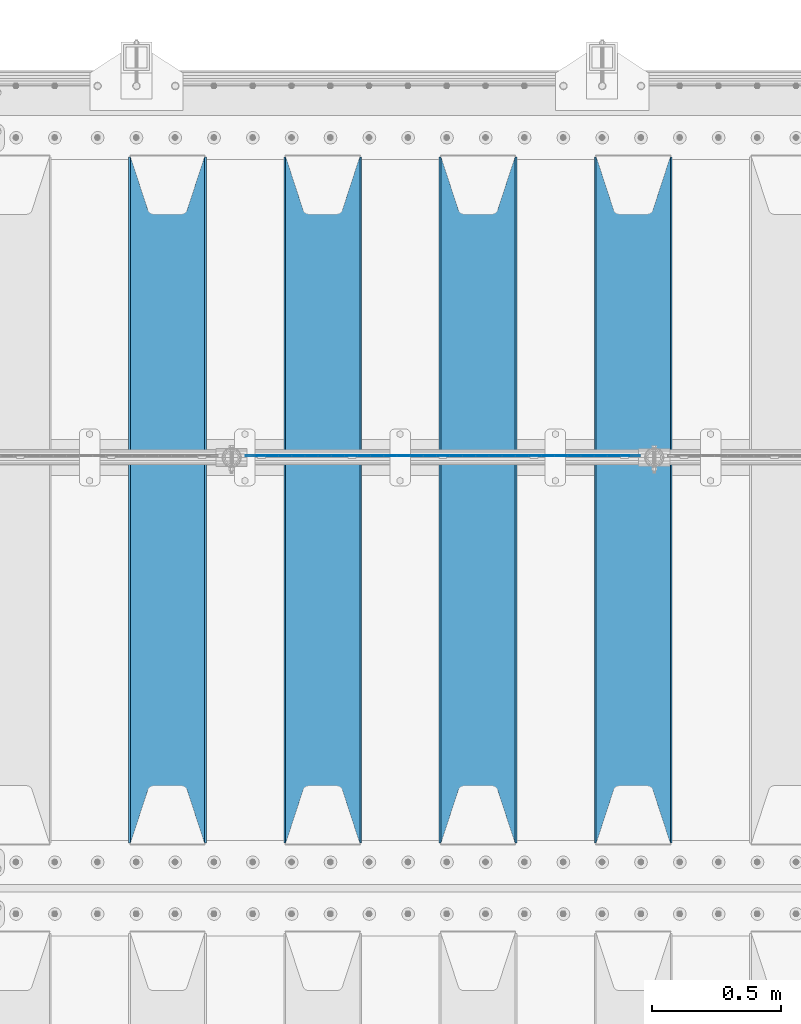
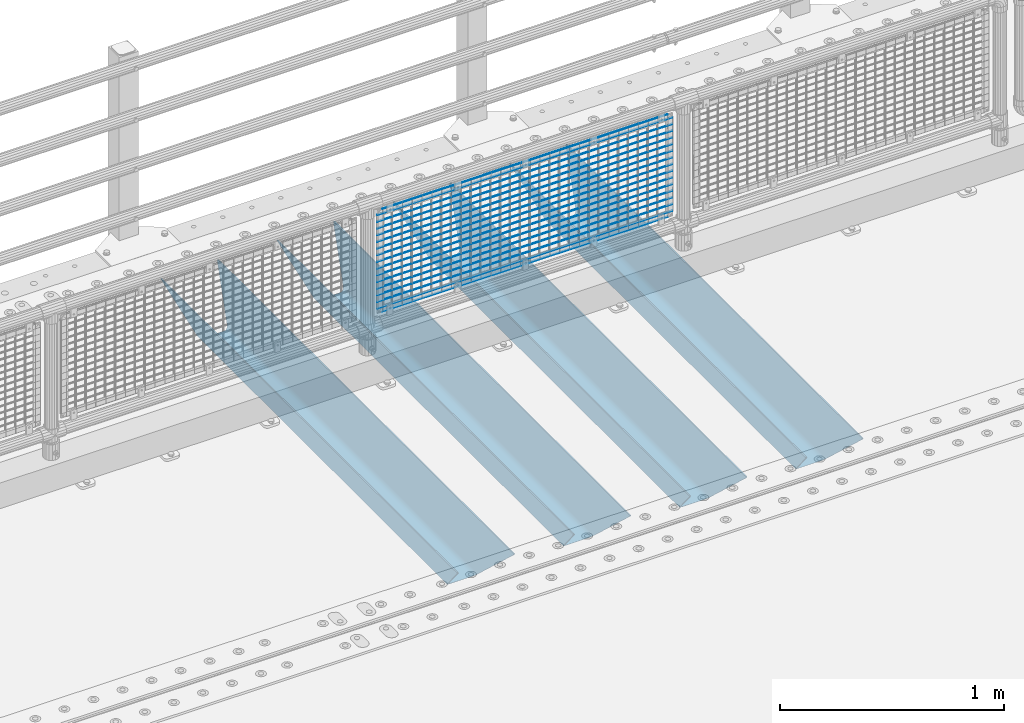
# One storey, part 145 of 270: 21 beams.
"""IFC2X3 building model written with IfcOpenShell, lengths in millimetres."""

from ifc_helpers import new_model, si_unit, frame, origin_with_axes, place, context, subcontext, project, spatial, faceted_brep, material, type_object, element, save


model = new_model("IFC2X3")

# Units and contexts
model_context = context("Model", 3, precision=1e-05, world=origin_with_axes())
body_context = subcontext(model_context, "Body", "Model", "MODEL_VIEW")
ifc_project = project(units=[si_unit("LENGTHUNIT", "METRE", prefix="MILLI"), si_unit("AREAUNIT", "SQUARE_METRE"), si_unit("VOLUMEUNIT", "CUBIC_METRE"), si_unit("MASSUNIT", "GRAM", prefix="KILO"), si_unit("TIMEUNIT", "SECOND"), si_unit("PLANEANGLEUNIT", "RADIAN"), si_unit("SOLIDANGLEUNIT", "STERADIAN"), si_unit("THERMODYNAMICTEMPERATUREUNIT", "DEGREE_CELSIUS"), si_unit("LUMINOUSINTENSITYUNIT", "LUMEN")], contexts=[model_context])

# Site, building, storey
site_placement = place(None, origin_with_axes())
site = spatial("IfcSite", under=ifc_project, at=site_placement, CompositionType="ELEMENT")
building_placement = place(site_placement, origin_with_axes())
building = spatial("IfcBuilding", under=site, at=building_placement, Name="Standard", CompositionType="ELEMENT")
storey_placement = place(building_placement, origin_with_axes())
storey = spatial("IfcBuildingStorey", under=building, at=storey_placement, Name="Undefined", CompositionType="ELEMENT", Elevation=0.0)

# Beams
ifc_material_1 = material(Name="STEEL/S355N")
beam_type_1 = type_object("IfcBeamType", PredefinedType="NOTDEFINED")
beam_1_placement = place(storey_placement, frame((16870.0, -17825.0, -115.0), z_axis=(0.0, 0.0, 1.0), x_axis=(0.0, 1.0, 0.0)))
element("IfcBeam", 1, at=beam_1_placement, inside=storey, type_object=beam_type_1, material=ifc_material_1, context=body_context, shape_type="Brep", body=[
    faceted_brep([(0.0, 150.0, 115.0), (0.0, 143.689999999999, 115.0), (2650.00000000297, 143.689999999999, 115.0), (2650.00000000297, 150.0, 115.0), (2650.00000000297, 142.059565218398, 110.000000003096), (2650.00000000297, 148.3695652184, 110.000000003096), (2441.90079219209, -80.1103600731112, -98.0992078077845), (2437.7588105432, -77.5672621345584, -102.241189456673), (2434.06523489747, -74.4080125315522, -105.934765102404), (2430.9108609509, -70.710272125576, -109.089139048974), (2428.37322971128, -66.5649389910068, -111.626770288588), (2426.51472138055, -62.0739139532889, -113.485278619323), (2425.38102192092, -57.3475956567672, -114.618978078955), (2424.99999999987, -52.5021667386536, -115.0), (2424.99999999987, 52.5021667386536, -115.0), (2425.38102192092, 57.3475956567672, -114.618978078955), (2426.51472138055, 62.0739139532889, -113.485278619323), (2428.37322971128, 66.5649389910068, -111.626770288588), (2430.9108609509, 70.710272125576, -109.089139048974), (2434.06523489747, 74.4080125315522, -105.934765102404), (2437.7588105432, 77.5672621345584, -102.241189456673), (2441.90079219209, 80.1103600731112, -98.0992078077846), (2446.38936140511, 81.9747917625791, -93.6106385947584), (2448.2494850041, 76.2713538057251, -91.7505149957729), (2444.62967112263, 74.76777986261, -95.3703288772456), (2441.28936334126, 72.7168944282894, -98.710636658607), (2438.31067330439, 70.1691124903846, -101.689326695487), (2435.76682334747, 67.1870637758839, -104.233176652398), (2433.72034654133, 63.8440531834895, -106.279653458539), (2432.22154950042, 60.222258798236, -107.778450499454), (2431.30727574265, 56.4107117849089, -108.692724257221), (2430.99999999987, 52.5031078186876, -109.0), (2430.99999999987, -52.5031078186876, -109.0), (2431.30727574265, -56.4107117849089, -108.692724257221), (2432.22154950042, -60.222258798236, -107.778450499454), (2433.72034654133, -63.8440531834895, -106.279653458539), (2435.76682334747, -67.1870637758839, -104.233176652398), (2438.31067330438, -70.1691124903846, -101.689326695487), (2441.28936334126, -72.7168944282894, -98.7106366586071), (2444.62967112263, -74.76777986261, -95.3703288772457), (2448.2494850041, -76.2713538057251, -91.7505149957729), (2650.00000000297, -142.059565218398, 110.000000003096), (2650.00000000297, -148.3695652184, 110.000000003096), (2446.38936140511, -81.9747917625791, -93.6106385947584), (2650.00000000297, -143.689999999999, 115.0), (2650.00000000297, -150.0, 115.0), (0.0, -143.689999999999, 115.0), (0.0, -150.0, 115.0), (0.0, -148.369565218261, 110.000000002672), (203.610638597431, -81.9747917625791, -93.6106385947584), (208.099207810457, -80.1103600731112, -98.0992078077845), (212.241189459342, -77.5672621345584, -102.241189456673), (215.934765105078, -74.4080125315522, -105.934765102404), (219.089139051644, -70.710272125576, -109.089139048974), (221.626770291259, -66.5649389910068, -111.626770288588), (223.485278621993, -62.0739139532889, -113.485278619323), (224.618978081628, -57.3475956567672, -114.618978078955), (225.00000000267, -52.5021667386536, -115.0), (225.00000000267, 52.5021667386536, -115.0), (224.618978081628, 57.3475956567672, -114.618978078955), (223.485278621993, 62.0739139532889, -113.485278619323), (221.626770291259, 66.5649389910068, -111.626770288588), (219.089139051644, 70.710272125576, -109.089139048974), (215.934765105078, 74.4080125315522, -105.934765102404), (212.241189459342, 77.5672621345584, -102.241189456673), (208.099207810457, 80.1103600731112, -98.0992078077846), (203.610638597431, 81.9747917625791, -93.6106385947584), (0.0, 148.369565218261, 110.000000002672), (0.0, 142.05956521826, 110.000000002672), (201.750514998446, 76.2713538057251, -91.7505149957729), (205.370328879915, 74.76777986261, -95.3703288772456), (208.710636661279, 72.7168944282894, -98.710636658607), (211.689326698157, 70.1691124903846, -101.689326695487), (214.233176655071, 67.1870637758839, -104.233176652398), (216.27965346121, 63.8440531834895, -106.279653458539), (217.778450502126, 60.222258798236, -107.778450499454), (218.692724259894, 56.4107117849089, -108.692724257221), (219.00000000267, 52.5031078186876, -109.0), (219.00000000267, -52.5031078186876, -109.0), (218.692724259894, -56.4107117849089, -108.692724257221), (217.778450502123, -60.222258798236, -107.778450499454), (216.27965346121, -63.8440531834895, -106.279653458539), (214.233176655071, -67.1870637758839, -104.233176652398), (211.689326698157, -70.1691124903846, -101.689326695487), (208.710636661279, -72.7168944282894, -98.7106366586071), (205.370328879915, -74.76777986261, -95.3703288772457), (201.750514998446, -76.2713538057251, -91.7505149957729), (0.0, -142.05956521826, 110.000000002672)], [[[0, 1, 2, 3]], [[3, 2, 4, 5]], [[6, 7, 8, 9, 10, 11, 12, 13, 14, 15, 16, 17, 18, 19, 20, 21, 22, 5, 4, 23, 24, 25, 26, 27, 28, 29, 30, 31, 32, 33, 34, 35, 36, 37, 38, 39, 40, 41, 42, 43]], [[44, 45, 42, 41]], [[46, 47, 45, 44]], [[43, 42, 45, 47, 48, 49]], [[6, 43, 49, 50]], [[7, 6, 50, 51]], [[8, 7, 51, 52]], [[9, 8, 52, 53]], [[10, 9, 53, 54]], [[11, 10, 54, 55]], [[12, 11, 55, 56]], [[13, 12, 56, 57]], [[14, 13, 57, 58]], [[15, 14, 58, 59]], [[16, 15, 59, 60]], [[17, 16, 60, 61]], [[18, 17, 61, 62]], [[19, 18, 62, 63]], [[20, 19, 63, 64]], [[21, 20, 64, 65]], [[22, 21, 65, 66]], [[0, 3, 5, 22, 66, 67]], [[1, 0, 67, 68]], [[23, 4, 2, 1, 68, 69]], [[24, 23, 69, 70]], [[25, 24, 70, 71]], [[26, 25, 71, 72]], [[27, 26, 72, 73]], [[28, 27, 73, 74]], [[29, 28, 74, 75]], [[30, 29, 75, 76]], [[31, 30, 76, 77]], [[32, 31, 77, 78]], [[33, 32, 78, 79]], [[34, 33, 79, 80]], [[35, 34, 80, 81]], [[36, 35, 81, 82]], [[37, 36, 82, 83]], [[38, 37, 83, 84]], [[39, 38, 84, 85]], [[40, 39, 85, 86]], [[46, 44, 41, 40, 86, 87]], [[47, 46, 87, 48]], [[86, 85, 84, 83, 82, 81, 80, 79, 78, 77, 76, 75, 74, 73, 72, 71, 70, 69, 68, 67, 66, 65, 64, 63, 62, 61, 60, 59, 58, 57, 56, 55, 54, 53, 52, 51, 50, 49, 48, 87]]]),
])
beam_2_placement = place(storey_placement, frame((16270.0, -17825.0, -115.0), z_axis=(0.0, 0.0, 1.0), x_axis=(0.0, 1.0, 0.0)))
element("IfcBeam", 2, at=beam_2_placement, inside=storey, type_object=beam_type_1, material=ifc_material_1, context=body_context, shape_type="Brep", body=[
    faceted_brep([(0.0, 150.0, 115.0), (0.0, 143.689999999999, 115.0), (2650.00000000297, 143.689999999999, 115.0), (2650.00000000297, 150.0, 115.0), (2650.00000000297, 142.059565218398, 110.000000003096), (2650.00000000297, 148.3695652184, 110.000000003096), (2441.90079219209, -80.1103600731112, -98.0992078077845), (2437.7588105432, -77.5672621345584, -102.241189456673), (2434.06523489747, -74.4080125315522, -105.934765102404), (2430.9108609509, -70.710272125576, -109.089139048974), (2428.37322971128, -66.5649389910068, -111.626770288588), (2426.51472138055, -62.0739139532889, -113.485278619323), (2425.38102192092, -57.3475956567672, -114.618978078955), (2424.99999999987, -52.5021667386536, -115.0), (2424.99999999987, 52.5021667386536, -115.0), (2425.38102192092, 57.3475956567672, -114.618978078955), (2426.51472138055, 62.0739139532889, -113.485278619323), (2428.37322971128, 66.5649389910068, -111.626770288588), (2430.9108609509, 70.710272125576, -109.089139048974), (2434.06523489747, 74.4080125315522, -105.934765102404), (2437.7588105432, 77.5672621345584, -102.241189456673), (2441.90079219209, 80.1103600731112, -98.0992078077846), (2446.38936140511, 81.9747917625791, -93.6106385947584), (2448.2494850041, 76.2713538057251, -91.7505149957729), (2444.62967112263, 74.76777986261, -95.3703288772456), (2441.28936334126, 72.7168944282894, -98.710636658607), (2438.31067330439, 70.1691124903846, -101.689326695487), (2435.76682334747, 67.1870637758839, -104.233176652398), (2433.72034654133, 63.8440531834895, -106.279653458539), (2432.22154950042, 60.222258798236, -107.778450499454), (2431.30727574265, 56.4107117849089, -108.692724257221), (2430.99999999987, 52.5031078186876, -109.0), (2430.99999999987, -52.5031078186876, -109.0), (2431.30727574265, -56.4107117849089, -108.692724257221), (2432.22154950042, -60.222258798236, -107.778450499454), (2433.72034654133, -63.8440531834895, -106.279653458539), (2435.76682334747, -67.1870637758839, -104.233176652398), (2438.31067330438, -70.1691124903846, -101.689326695487), (2441.28936334126, -72.7168944282894, -98.7106366586071), (2444.62967112263, -74.76777986261, -95.3703288772457), (2448.2494850041, -76.2713538057251, -91.7505149957729), (2650.00000000297, -142.059565218398, 110.000000003096), (2650.00000000297, -148.3695652184, 110.000000003096), (2446.38936140511, -81.9747917625791, -93.6106385947584), (2650.00000000297, -143.689999999999, 115.0), (2650.00000000297, -150.0, 115.0), (0.0, -143.689999999999, 115.0), (0.0, -150.0, 115.0), (0.0, -148.369565218261, 110.000000002672), (203.610638597431, -81.9747917625791, -93.6106385947584), (208.099207810457, -80.1103600731112, -98.0992078077845), (212.241189459342, -77.5672621345584, -102.241189456673), (215.934765105078, -74.4080125315522, -105.934765102404), (219.089139051644, -70.710272125576, -109.089139048974), (221.626770291259, -66.5649389910068, -111.626770288588), (223.485278621993, -62.0739139532889, -113.485278619323), (224.618978081628, -57.3475956567672, -114.618978078955), (225.00000000267, -52.5021667386536, -115.0), (225.00000000267, 52.5021667386536, -115.0), (224.618978081628, 57.3475956567672, -114.618978078955), (223.485278621993, 62.0739139532889, -113.485278619323), (221.626770291259, 66.5649389910068, -111.626770288588), (219.089139051644, 70.710272125576, -109.089139048974), (215.934765105078, 74.4080125315522, -105.934765102404), (212.241189459342, 77.5672621345584, -102.241189456673), (208.099207810457, 80.1103600731112, -98.0992078077846), (203.610638597431, 81.9747917625791, -93.6106385947584), (0.0, 148.369565218261, 110.000000002672), (0.0, 142.05956521826, 110.000000002672), (201.750514998446, 76.2713538057251, -91.7505149957729), (205.370328879915, 74.76777986261, -95.3703288772456), (208.710636661279, 72.7168944282894, -98.710636658607), (211.689326698157, 70.1691124903846, -101.689326695487), (214.233176655071, 67.1870637758839, -104.233176652398), (216.27965346121, 63.8440531834895, -106.279653458539), (217.778450502126, 60.222258798236, -107.778450499454), (218.692724259894, 56.4107117849089, -108.692724257221), (219.00000000267, 52.5031078186876, -109.0), (219.00000000267, -52.5031078186876, -109.0), (218.692724259894, -56.4107117849089, -108.692724257221), (217.778450502123, -60.222258798236, -107.778450499454), (216.27965346121, -63.8440531834895, -106.279653458539), (214.233176655071, -67.1870637758839, -104.233176652398), (211.689326698157, -70.1691124903846, -101.689326695487), (208.710636661279, -72.7168944282894, -98.7106366586071), (205.370328879915, -74.76777986261, -95.3703288772457), (201.750514998446, -76.2713538057251, -91.7505149957729), (0.0, -142.05956521826, 110.000000002672)], [[[0, 1, 2, 3]], [[3, 2, 4, 5]], [[6, 7, 8, 9, 10, 11, 12, 13, 14, 15, 16, 17, 18, 19, 20, 21, 22, 5, 4, 23, 24, 25, 26, 27, 28, 29, 30, 31, 32, 33, 34, 35, 36, 37, 38, 39, 40, 41, 42, 43]], [[44, 45, 42, 41]], [[46, 47, 45, 44]], [[43, 42, 45, 47, 48, 49]], [[6, 43, 49, 50]], [[7, 6, 50, 51]], [[8, 7, 51, 52]], [[9, 8, 52, 53]], [[10, 9, 53, 54]], [[11, 10, 54, 55]], [[12, 11, 55, 56]], [[13, 12, 56, 57]], [[14, 13, 57, 58]], [[15, 14, 58, 59]], [[16, 15, 59, 60]], [[17, 16, 60, 61]], [[18, 17, 61, 62]], [[19, 18, 62, 63]], [[20, 19, 63, 64]], [[21, 20, 64, 65]], [[22, 21, 65, 66]], [[0, 3, 5, 22, 66, 67]], [[1, 0, 67, 68]], [[23, 4, 2, 1, 68, 69]], [[24, 23, 69, 70]], [[25, 24, 70, 71]], [[26, 25, 71, 72]], [[27, 26, 72, 73]], [[28, 27, 73, 74]], [[29, 28, 74, 75]], [[30, 29, 75, 76]], [[31, 30, 76, 77]], [[32, 31, 77, 78]], [[33, 32, 78, 79]], [[34, 33, 79, 80]], [[35, 34, 80, 81]], [[36, 35, 81, 82]], [[37, 36, 82, 83]], [[38, 37, 83, 84]], [[39, 38, 84, 85]], [[40, 39, 85, 86]], [[46, 44, 41, 40, 86, 87]], [[47, 46, 87, 48]], [[86, 85, 84, 83, 82, 81, 80, 79, 78, 77, 76, 75, 74, 73, 72, 71, 70, 69, 68, 67, 66, 65, 64, 63, 62, 61, 60, 59, 58, 57, 56, 55, 54, 53, 52, 51, 50, 49, 48, 87]]]),
])
beam_3_placement = place(storey_placement, frame((15670.0, -17825.0, -115.0), z_axis=(0.0, 0.0, 1.0), x_axis=(0.0, 1.0, 0.0)))
element("IfcBeam", 3, at=beam_3_placement, inside=storey, type_object=beam_type_1, material=ifc_material_1, context=body_context, shape_type="Brep", body=[
    faceted_brep([(0.0, 150.0, 115.0), (0.0, 143.689999999999, 115.0), (2650.00000000297, 143.689999999999, 115.0), (2650.00000000297, 150.0, 115.0), (2650.00000000297, 142.059565218398, 110.000000003096), (2650.00000000297, 148.3695652184, 110.000000003096), (2441.90079219209, -80.1103600731112, -98.0992078077845), (2437.7588105432, -77.5672621345584, -102.241189456673), (2434.06523489747, -74.4080125315522, -105.934765102404), (2430.9108609509, -70.710272125576, -109.089139048974), (2428.37322971128, -66.5649389910068, -111.626770288588), (2426.51472138055, -62.0739139532889, -113.485278619323), (2425.38102192092, -57.3475956567672, -114.618978078955), (2424.99999999987, -52.5021667386536, -115.0), (2424.99999999987, 52.5021667386536, -115.0), (2425.38102192092, 57.3475956567672, -114.618978078955), (2426.51472138055, 62.0739139532889, -113.485278619323), (2428.37322971128, 66.5649389910068, -111.626770288588), (2430.9108609509, 70.710272125576, -109.089139048974), (2434.06523489747, 74.4080125315522, -105.934765102404), (2437.7588105432, 77.5672621345584, -102.241189456673), (2441.90079219209, 80.1103600731112, -98.0992078077846), (2446.38936140511, 81.9747917625791, -93.6106385947584), (2448.2494850041, 76.2713538057251, -91.7505149957729), (2444.62967112263, 74.76777986261, -95.3703288772456), (2441.28936334126, 72.7168944282894, -98.710636658607), (2438.31067330439, 70.1691124903846, -101.689326695487), (2435.76682334747, 67.1870637758839, -104.233176652398), (2433.72034654133, 63.8440531834895, -106.279653458539), (2432.22154950042, 60.222258798236, -107.778450499454), (2431.30727574265, 56.4107117849089, -108.692724257221), (2430.99999999987, 52.5031078186876, -109.0), (2430.99999999987, -52.5031078186876, -109.0), (2431.30727574265, -56.4107117849089, -108.692724257221), (2432.22154950042, -60.222258798236, -107.778450499454), (2433.72034654133, -63.8440531834895, -106.279653458539), (2435.76682334747, -67.1870637758839, -104.233176652398), (2438.31067330438, -70.1691124903846, -101.689326695487), (2441.28936334126, -72.7168944282894, -98.7106366586071), (2444.62967112263, -74.76777986261, -95.3703288772457), (2448.2494850041, -76.2713538057251, -91.7505149957729), (2650.00000000297, -142.059565218398, 110.000000003096), (2650.00000000297, -148.3695652184, 110.000000003096), (2446.38936140511, -81.9747917625791, -93.6106385947584), (2650.00000000297, -143.689999999999, 115.0), (2650.00000000297, -150.0, 115.0), (0.0, -143.689999999999, 115.0), (0.0, -150.0, 115.0), (0.0, -148.369565218261, 110.000000002672), (203.610638597431, -81.9747917625791, -93.6106385947584), (208.099207810457, -80.1103600731112, -98.0992078077845), (212.241189459342, -77.5672621345584, -102.241189456673), (215.934765105078, -74.4080125315522, -105.934765102404), (219.089139051644, -70.710272125576, -109.089139048974), (221.626770291259, -66.5649389910068, -111.626770288588), (223.485278621993, -62.0739139532889, -113.485278619323), (224.618978081628, -57.3475956567672, -114.618978078955), (225.00000000267, -52.5021667386536, -115.0), (225.00000000267, 52.5021667386536, -115.0), (224.618978081628, 57.3475956567672, -114.618978078955), (223.485278621993, 62.0739139532889, -113.485278619323), (221.626770291259, 66.5649389910068, -111.626770288588), (219.089139051644, 70.710272125576, -109.089139048974), (215.934765105078, 74.4080125315522, -105.934765102404), (212.241189459342, 77.5672621345584, -102.241189456673), (208.099207810457, 80.1103600731112, -98.0992078077846), (203.610638597431, 81.9747917625791, -93.6106385947584), (0.0, 148.369565218261, 110.000000002672), (0.0, 142.05956521826, 110.000000002672), (201.750514998446, 76.2713538057251, -91.7505149957729), (205.370328879915, 74.76777986261, -95.3703288772456), (208.710636661279, 72.7168944282894, -98.710636658607), (211.689326698157, 70.1691124903846, -101.689326695487), (214.233176655071, 67.1870637758839, -104.233176652398), (216.27965346121, 63.8440531834895, -106.279653458539), (217.778450502126, 60.222258798236, -107.778450499454), (218.692724259894, 56.4107117849089, -108.692724257221), (219.00000000267, 52.5031078186876, -109.0), (219.00000000267, -52.5031078186876, -109.0), (218.692724259894, -56.4107117849089, -108.692724257221), (217.778450502123, -60.222258798236, -107.778450499454), (216.27965346121, -63.8440531834895, -106.279653458539), (214.233176655071, -67.1870637758839, -104.233176652398), (211.689326698157, -70.1691124903846, -101.689326695487), (208.710636661279, -72.7168944282894, -98.7106366586071), (205.370328879915, -74.76777986261, -95.3703288772457), (201.750514998446, -76.2713538057251, -91.7505149957729), (0.0, -142.05956521826, 110.000000002672)], [[[0, 1, 2, 3]], [[3, 2, 4, 5]], [[6, 7, 8, 9, 10, 11, 12, 13, 14, 15, 16, 17, 18, 19, 20, 21, 22, 5, 4, 23, 24, 25, 26, 27, 28, 29, 30, 31, 32, 33, 34, 35, 36, 37, 38, 39, 40, 41, 42, 43]], [[44, 45, 42, 41]], [[46, 47, 45, 44]], [[43, 42, 45, 47, 48, 49]], [[6, 43, 49, 50]], [[7, 6, 50, 51]], [[8, 7, 51, 52]], [[9, 8, 52, 53]], [[10, 9, 53, 54]], [[11, 10, 54, 55]], [[12, 11, 55, 56]], [[13, 12, 56, 57]], [[14, 13, 57, 58]], [[15, 14, 58, 59]], [[16, 15, 59, 60]], [[17, 16, 60, 61]], [[18, 17, 61, 62]], [[19, 18, 62, 63]], [[20, 19, 63, 64]], [[21, 20, 64, 65]], [[22, 21, 65, 66]], [[0, 3, 5, 22, 66, 67]], [[1, 0, 67, 68]], [[23, 4, 2, 1, 68, 69]], [[24, 23, 69, 70]], [[25, 24, 70, 71]], [[26, 25, 71, 72]], [[27, 26, 72, 73]], [[28, 27, 73, 74]], [[29, 28, 74, 75]], [[30, 29, 75, 76]], [[31, 30, 76, 77]], [[32, 31, 77, 78]], [[33, 32, 78, 79]], [[34, 33, 79, 80]], [[35, 34, 80, 81]], [[36, 35, 81, 82]], [[37, 36, 82, 83]], [[38, 37, 83, 84]], [[39, 38, 84, 85]], [[40, 39, 85, 86]], [[46, 44, 41, 40, 86, 87]], [[47, 46, 87, 48]], [[86, 85, 84, 83, 82, 81, 80, 79, 78, 77, 76, 75, 74, 73, 72, 71, 70, 69, 68, 67, 66, 65, 64, 63, 62, 61, 60, 59, 58, 57, 56, 55, 54, 53, 52, 51, 50, 49, 48, 87]]]),
])
beam_4_placement = place(storey_placement, frame((15070.0, -17825.0, -115.0), z_axis=(0.0, 0.0, 1.0), x_axis=(0.0, 1.0, 0.0)))
element("IfcBeam", 4, at=beam_4_placement, inside=storey, type_object=beam_type_1, material=ifc_material_1, context=body_context, shape_type="Brep", body=[
    faceted_brep([(0.0, 150.0, 115.0), (0.0, 143.689999999999, 115.0), (2650.00000000297, 143.689999999999, 115.0), (2650.00000000297, 150.0, 115.0), (2650.00000000297, 142.059565218398, 110.000000003096), (2650.00000000297, 148.3695652184, 110.000000003096), (2441.90079219209, -80.1103600731112, -98.0992078077845), (2437.7588105432, -77.5672621345584, -102.241189456673), (2434.06523489747, -74.4080125315522, -105.934765102404), (2430.9108609509, -70.710272125576, -109.089139048974), (2428.37322971128, -66.5649389910068, -111.626770288588), (2426.51472138055, -62.0739139532889, -113.485278619323), (2425.38102192092, -57.3475956567672, -114.618978078955), (2424.99999999987, -52.5021667386536, -115.0), (2424.99999999987, 52.5021667386536, -115.0), (2425.38102192092, 57.3475956567672, -114.618978078955), (2426.51472138055, 62.0739139532889, -113.485278619323), (2428.37322971128, 66.5649389910068, -111.626770288588), (2430.9108609509, 70.710272125576, -109.089139048974), (2434.06523489747, 74.4080125315522, -105.934765102404), (2437.7588105432, 77.5672621345584, -102.241189456673), (2441.90079219209, 80.1103600731112, -98.0992078077846), (2446.38936140511, 81.9747917625791, -93.6106385947584), (2448.2494850041, 76.2713538057251, -91.7505149957729), (2444.62967112263, 74.76777986261, -95.3703288772456), (2441.28936334126, 72.7168944282894, -98.710636658607), (2438.31067330439, 70.1691124903846, -101.689326695487), (2435.76682334747, 67.1870637758839, -104.233176652398), (2433.72034654133, 63.8440531834895, -106.279653458539), (2432.22154950042, 60.222258798236, -107.778450499454), (2431.30727574265, 56.4107117849089, -108.692724257221), (2430.99999999987, 52.5031078186876, -109.0), (2430.99999999987, -52.5031078186876, -109.0), (2431.30727574265, -56.4107117849089, -108.692724257221), (2432.22154950042, -60.222258798236, -107.778450499454), (2433.72034654133, -63.8440531834895, -106.279653458539), (2435.76682334747, -67.1870637758839, -104.233176652398), (2438.31067330438, -70.1691124903846, -101.689326695487), (2441.28936334126, -72.7168944282894, -98.7106366586071), (2444.62967112263, -74.76777986261, -95.3703288772457), (2448.2494850041, -76.2713538057251, -91.7505149957729), (2650.00000000297, -142.059565218398, 110.000000003096), (2650.00000000297, -148.3695652184, 110.000000003096), (2446.38936140511, -81.9747917625791, -93.6106385947584), (2650.00000000297, -143.689999999999, 115.0), (2650.00000000297, -150.0, 115.0), (0.0, -143.689999999999, 115.0), (0.0, -150.0, 115.0), (0.0, -148.369565218261, 110.000000002672), (203.610638597431, -81.9747917625791, -93.6106385947584), (208.099207810457, -80.1103600731112, -98.0992078077845), (212.241189459342, -77.5672621345584, -102.241189456673), (215.934765105078, -74.4080125315522, -105.934765102404), (219.089139051644, -70.710272125576, -109.089139048974), (221.626770291259, -66.5649389910068, -111.626770288588), (223.485278621993, -62.0739139532889, -113.485278619323), (224.618978081628, -57.3475956567672, -114.618978078955), (225.00000000267, -52.5021667386536, -115.0), (225.00000000267, 52.5021667386536, -115.0), (224.618978081628, 57.3475956567672, -114.618978078955), (223.485278621993, 62.0739139532889, -113.485278619323), (221.626770291259, 66.5649389910068, -111.626770288588), (219.089139051644, 70.710272125576, -109.089139048974), (215.934765105078, 74.4080125315522, -105.934765102404), (212.241189459342, 77.5672621345584, -102.241189456673), (208.099207810457, 80.1103600731112, -98.0992078077846), (203.610638597431, 81.9747917625791, -93.6106385947584), (0.0, 148.369565218261, 110.000000002672), (0.0, 142.05956521826, 110.000000002672), (201.750514998446, 76.2713538057251, -91.7505149957729), (205.370328879915, 74.76777986261, -95.3703288772456), (208.710636661279, 72.7168944282894, -98.710636658607), (211.689326698157, 70.1691124903846, -101.689326695487), (214.233176655071, 67.1870637758839, -104.233176652398), (216.27965346121, 63.8440531834895, -106.279653458539), (217.778450502126, 60.222258798236, -107.778450499454), (218.692724259894, 56.4107117849089, -108.692724257221), (219.00000000267, 52.5031078186876, -109.0), (219.00000000267, -52.5031078186876, -109.0), (218.692724259894, -56.4107117849089, -108.692724257221), (217.778450502123, -60.222258798236, -107.778450499454), (216.27965346121, -63.8440531834895, -106.279653458539), (214.233176655071, -67.1870637758839, -104.233176652398), (211.689326698157, -70.1691124903846, -101.689326695487), (208.710636661279, -72.7168944282894, -98.7106366586071), (205.370328879915, -74.76777986261, -95.3703288772457), (201.750514998446, -76.2713538057251, -91.7505149957729), (0.0, -142.05956521826, 110.000000002672)], [[[0, 1, 2, 3]], [[3, 2, 4, 5]], [[6, 7, 8, 9, 10, 11, 12, 13, 14, 15, 16, 17, 18, 19, 20, 21, 22, 5, 4, 23, 24, 25, 26, 27, 28, 29, 30, 31, 32, 33, 34, 35, 36, 37, 38, 39, 40, 41, 42, 43]], [[44, 45, 42, 41]], [[46, 47, 45, 44]], [[43, 42, 45, 47, 48, 49]], [[6, 43, 49, 50]], [[7, 6, 50, 51]], [[8, 7, 51, 52]], [[9, 8, 52, 53]], [[10, 9, 53, 54]], [[11, 10, 54, 55]], [[12, 11, 55, 56]], [[13, 12, 56, 57]], [[14, 13, 57, 58]], [[15, 14, 58, 59]], [[16, 15, 59, 60]], [[17, 16, 60, 61]], [[18, 17, 61, 62]], [[19, 18, 62, 63]], [[20, 19, 63, 64]], [[21, 20, 64, 65]], [[22, 21, 65, 66]], [[0, 3, 5, 22, 66, 67]], [[1, 0, 67, 68]], [[23, 4, 2, 1, 68, 69]], [[24, 23, 69, 70]], [[25, 24, 70, 71]], [[26, 25, 71, 72]], [[27, 26, 72, 73]], [[28, 27, 73, 74]], [[29, 28, 74, 75]], [[30, 29, 75, 76]], [[31, 30, 76, 77]], [[32, 31, 77, 78]], [[33, 32, 78, 79]], [[34, 33, 79, 80]], [[35, 34, 80, 81]], [[36, 35, 81, 82]], [[37, 36, 82, 83]], [[38, 37, 83, 84]], [[39, 38, 84, 85]], [[40, 39, 85, 86]], [[46, 44, 41, 40, 86, 87]], [[47, 46, 87, 48]], [[86, 85, 84, 83, 82, 81, 80, 79, 78, 77, 76, 75, 74, 73, 72, 71, 70, 69, 68, 67, 66, 65, 64, 63, 62, 61, 60, 59, 58, 57, 56, 55, 54, 53, 52, 51, 50, 49, 48, 87]]]),
])
ifc_material_2 = material(Name="Misc_Undefined")
beam_type_2 = type_object("IfcBeamType", Name="D3", PredefinedType="NOTDEFINED")
for number, where, z_axis, x_axis in (
    (5, (15373.0, -16329.5, 851.596999999999), (0.0, 0.0, 1.0), (1.0, 0.0, 0.0)),
    (6, (15373.0, -16329.5, 669.452), (0.0, 0.0, 1.0), (1.0, 0.0, 0.0)),
    (7, (15373.0, -16329.5, 523.736), (0.0, 0.0, 1.0), (1.0, 0.0, 0.0)),
    (8, (15373.0, -16329.5, 487.307), (0.0, 0.0, 1.0), (1.0, 0.0, 0.0)),
    (9, (15373.0, -16329.5, 705.881), (0.0, 0.0, 1.0), (1.0, 0.0, 0.0)),
    (10, (15373.0, -16329.5, 596.594), (0.0, 0.0, 1.0), (1.0, 0.0, 0.0)),
    (11, (15373.0, -16329.5, 450.878), (0.0, 0.0, 1.0), (1.0, 0.0, 0.0)),
    (12, (15373.0, -16329.5, 815.167999999999), (0.0, 0.0, 1.0), (1.0, 0.0, 0.0)),
    (13, (15373.0, -16329.5, 888.025999999999), (0.0, 0.0, 1.0), (1.0, 0.0, 0.0)),
    (14, (15373.0, -16329.5, 778.738999999999), (0.0, 0.0, 1.0), (1.0, 0.0, 0.0)),
    (15, (15373.0, -16329.5, 742.309999999999), (0.0, 0.0, 1.0), (1.0, 0.0, 0.0)),
    (16, (15373.0, -16329.5, 633.023), (0.0, 0.0, 1.0), (1.0, 0.0, 0.0)),
    (17, (15373.0, -16329.5, 560.165), (0.0, 0.0, 1.0), (1.0, 0.0, 0.0)),
    (18, (15373.0, -16329.5, 414.449), (0.0, 0.0, 1.0), (1.0, 0.0, 0.0)),
):
    element("IfcBeam", number, at=place(storey_placement, frame(where, z_axis=z_axis, x_axis=x_axis)), inside=storey, type_object=beam_type_2, material=ifc_material_2, ObjectType="D3", context=body_context, shape_type="Brep", body=[
        faceted_brep([(0.0, -1.5, 0.0), (0.0, -0.75, -1.29903810567669), (1523.0, -0.75, -1.29903810567669), (1523.0, -1.5, 0.0), (0.0, 0.75, -1.29903810567669), (1523.0, 0.75, -1.29903810567669), (0.0, 1.5, 0.0), (1523.0, 1.5, 0.0), (0.0, 0.75, 1.29903810567669), (1523.0, 0.75, 1.29903810567669), (0.0, -0.75, 1.29903810567669), (1523.0, -0.75, 1.29903810567669)], [[[0, 1, 2, 3]], [[1, 4, 5, 2]], [[4, 6, 7, 5]], [[6, 8, 9, 7]], [[8, 10, 11, 9]], [[10, 0, 3, 11]], [[5, 7, 9, 11, 3, 2]], [[10, 8, 6, 4, 1, 0]]]),
    ])
beam_5_placement = place(storey_placement, frame((15398.0, -16329.5, 353.02), z_axis=(0.0, 0.0, 1.0), x_axis=(1.0, 0.0, 0.0)))
element("IfcBeam", 19, at=beam_5_placement, inside=storey, type_object=beam_type_2, material=ifc_material_2, ObjectType="D3", context=body_context, shape_type="Brep", body=[
    faceted_brep([(0.0, -1.5, 0.0), (0.0, -0.75, -1.29903810567669), (1473.0, -0.75, -1.29903810567669), (1473.0, -1.5, 0.0), (0.0, 0.75, -1.29903810567669), (1473.0, 0.75, -1.29903810567663), (0.0, 1.5, 0.0), (1473.0, 1.5, 0.0), (0.0, 0.75, 1.29903810567669), (1473.0, 0.75, 1.29903810567669), (0.0, -0.75, 1.29903810567669), (1473.0, -0.75, 1.29903810567669)], [[[0, 1, 2, 3]], [[1, 4, 5, 2]], [[4, 6, 7, 5]], [[6, 8, 9, 7]], [[8, 10, 11, 9]], [[10, 0, 3, 11]], [[5, 7, 9, 11, 3, 2]], [[10, 8, 6, 4, 1, 0]]]),
])
beam_6_placement = place(storey_placement, frame((15373.0, -16329.5, 378.02), z_axis=(0.0, 0.0, 1.0), x_axis=(1.0, 0.0, 0.0)))
element("IfcBeam", 20, at=beam_6_placement, inside=storey, type_object=beam_type_2, material=ifc_material_2, ObjectType="D3", context=body_context, shape_type="Brep", body=[
    faceted_brep([(0.0, -1.5, 0.0), (0.0, -0.75, -1.29903810567669), (1523.0, -0.75, -1.29903810567669), (1523.0, -1.5, 0.0), (0.0, 0.75, -1.29903810567669), (1523.0, 0.75, -1.29903810567669), (0.0, 1.5, 0.0), (1523.0, 1.5, 0.0), (0.0, 0.75, 1.29903810567669), (1523.0, 0.75, 1.29903810567669), (0.0, -0.75, 1.29903810567669), (1523.0, -0.75, 1.29903810567669)], [[[0, 1, 2, 3]], [[1, 4, 5, 2]], [[4, 6, 7, 5]], [[6, 8, 9, 7]], [[8, 10, 11, 9]], [[10, 0, 3, 11]], [[5, 7, 9, 11, 3, 2]], [[10, 8, 6, 4, 1, 0]]]),
])
beam_7_placement = place(storey_placement, frame((15398.0, -16329.5, 913.02), z_axis=(0.0, 0.0, 1.0), x_axis=(1.0, 0.0, 0.0)))
element("IfcBeam", 21, at=beam_7_placement, inside=storey, type_object=beam_type_2, material=ifc_material_2, ObjectType="D3", context=body_context, shape_type="Brep", body=[
    faceted_brep([(0.0, -1.5, 0.0), (0.0, -0.75, -1.29903810567669), (1473.0, -0.75, -1.29903810567669), (1473.0, -1.5, 0.0), (0.0, 0.75, -1.29903810567669), (1473.0, 0.75, -1.29903810567663), (0.0, 1.5, 0.0), (1473.0, 1.5, 0.0), (0.0, 0.75, 1.29903810567669), (1473.0, 0.75, 1.29903810567669), (0.0, -0.75, 1.29903810567669), (1473.0, -0.75, 1.29903810567669)], [[[0, 1, 2, 3]], [[1, 4, 5, 2]], [[4, 6, 7, 5]], [[6, 8, 9, 7]], [[8, 10, 11, 9]], [[10, 0, 3, 11]], [[5, 7, 9, 11, 3, 2]], [[10, 8, 6, 4, 1, 0]]]),
])

save(model, "model.ifc")
